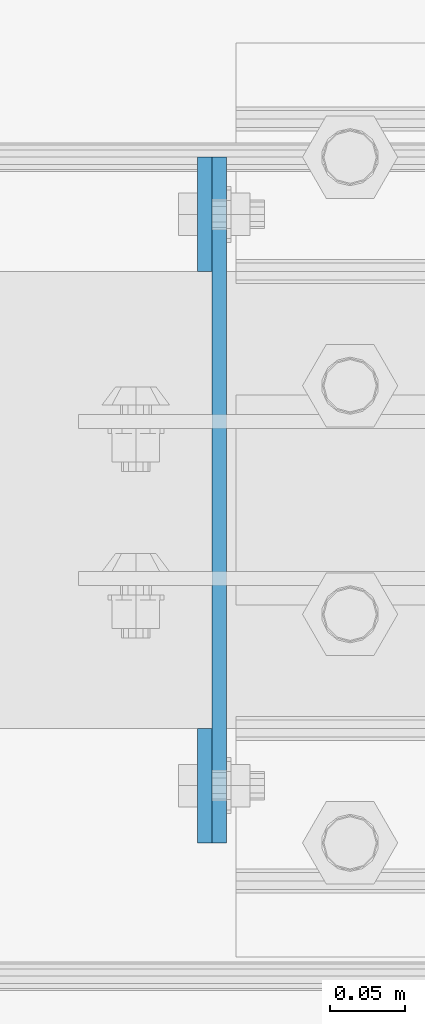
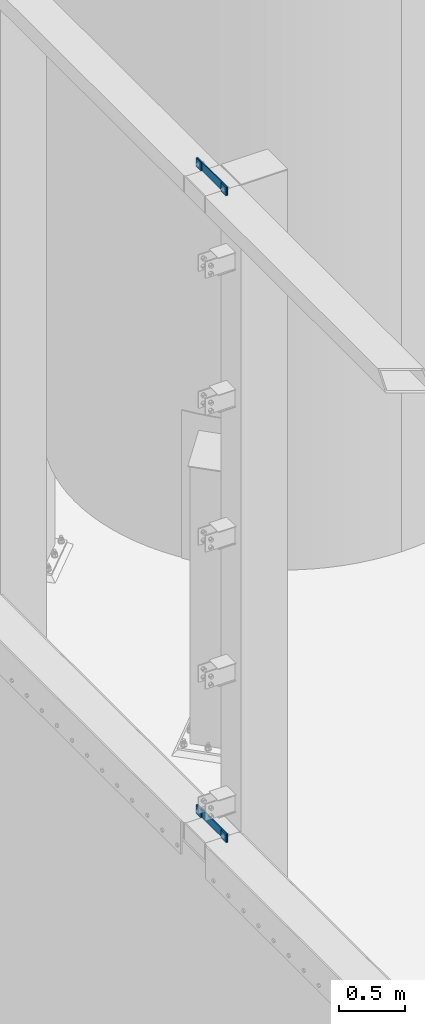
# One storey, part 1409 of 1876: 6 plates, 5 elements without a shape of their own.
"""IFC2X3 building model written with IfcOpenShell, lengths in millimetres."""

from ifc_helpers import new_model, si_unit, frame, origin_with_axes, place, context, subcontext, project, spatial, faceted_brep, material, type_object, element, aggregate, save


model = new_model("IFC2X3")

# Units and contexts
model_context = context("Model", 3, precision=1e-05, world=origin_with_axes())
body_context = subcontext(model_context, "Body", "Model", "MODEL_VIEW")
ifc_project = project(units=[si_unit("LENGTHUNIT", "METRE", prefix="MILLI"), si_unit("AREAUNIT", "SQUARE_METRE"), si_unit("VOLUMEUNIT", "CUBIC_METRE"), si_unit("MASSUNIT", "GRAM", prefix="KILO"), si_unit("TIMEUNIT", "SECOND"), si_unit("PLANEANGLEUNIT", "RADIAN"), si_unit("SOLIDANGLEUNIT", "STERADIAN"), si_unit("THERMODYNAMICTEMPERATUREUNIT", "DEGREE_CELSIUS"), si_unit("LUMINOUSINTENSITYUNIT", "LUMEN")], contexts=[model_context])

# Site, building, storey
site_placement = place(None, origin_with_axes())
site = spatial("IfcSite", under=ifc_project, at=site_placement, CompositionType="ELEMENT")
building_placement = place(site_placement, origin_with_axes())
building = spatial("IfcBuilding", under=site, at=building_placement, Name="Undefined", CompositionType="ELEMENT")
storey_placement = place(building_placement, origin_with_axes())
storey = spatial("IfcBuildingStorey", under=building, at=storey_placement, Name="Undefined", CompositionType="ELEMENT", Elevation=0.0)

# Assembly, plate
assembly_1_placement = place(storey_placement, origin_with_axes())
assembly_1 = element("IfcElementAssembly", 1, at=assembly_1_placement, inside=storey, Name="BEAM", AssemblyPlace="NOTDEFINED", PredefinedType="RIGID_FRAME")
ifc_material = material(Name="STEEL/A36")
plate_type = type_object("IfcPlateType", PredefinedType="NOTDEFINED")
plate_1_placement = place(assembly_1_placement, frame((-144.4625, -21894.8, 10667.9356518697), z_axis=(0.0, -1.0, 0.0), x_axis=(0.0, 0.0, 1.0)))
plate_1 = element("IfcPlate", 2, at=plate_1_placement, type_object=plate_type, material=ifc_material, Name="PLATE", context=body_context, shape_type="Brep", body=[
    faceted_brep([(0.0, -4.76249999999982, 0.0), (0.0643511861562729, -4.76249999999999, 76.1999969482422), (0.0643511861562729, 4.76249999999999, 76.1999969482422), (0.0, 4.76249999999982, 0.0), (76.2643508911133, -4.76249999999999, 76.1999969482422), (76.2643508911133, 4.76249999999999, 76.1999969482422), (76.2643508911133, -4.76249999999999, 0.0), (76.2643508911133, 4.76249999999999, 0.0)], [[[0, 1, 2, 3]], [[1, 4, 5, 2]], [[4, 6, 7, 5]], [[6, 0, 3, 7]], [[5, 7, 3, 2]], [[6, 4, 1, 0]]]),
])
aggregate(assembly_1, [plate_1])

assembly_2_placement = place(storey_placement, origin_with_axes())
assembly_2 = element("IfcElementAssembly", 3, at=assembly_2_placement, inside=storey, Name="BEAM", AssemblyPlace="NOTDEFINED", PredefinedType="RIGID_FRAME")
plate_2_placement = place(assembly_2_placement, frame((-144.4625, -21513.8, 10667.9356518697), z_axis=(0.0, -1.0, 0.0), x_axis=(0.0, 0.0, 1.0)))
plate_2 = element("IfcPlate", 4, at=plate_2_placement, type_object=plate_type, material=ifc_material, Name="PLATE", context=body_context, shape_type="Brep", body=[
    faceted_brep([(0.0, -4.76249999999982, 0.0), (0.0643511861562729, -4.76249999999999, 76.1999969482422), (0.0643511861562729, 4.76249999999999, 76.1999969482422), (0.0, 4.76249999999982, 0.0), (76.2643508911133, -4.76249999999999, 76.1999969482422), (76.2643508911133, 4.76249999999999, 76.1999969482422), (76.2643508911133, -4.76249999999999, 0.0), (76.2643508911133, 4.76249999999999, 0.0)], [[[0, 1, 2, 3]], [[1, 4, 5, 2]], [[4, 6, 7, 5]], [[6, 0, 3, 7]], [[5, 7, 3, 2]], [[6, 4, 1, 0]]]),
])
aggregate(assembly_2, [plate_2])

assembly_3_placement = place(storey_placement, origin_with_axes())
assembly_3 = element("IfcElementAssembly", 5, at=assembly_3_placement, inside=storey, Name="COLUMN", AssemblyPlace="NOTDEFINED", PredefinedType="RIGID_FRAME")
plate_3_placement = place(assembly_3_placement, frame((-134.9375, -21971.0, 10744.2), z_axis=(0.0, 1.0, 0.0), x_axis=(0.0, 0.0, -1.0)))
plate_3 = element("IfcPlate", 6, at=plate_3_placement, type_object=plate_type, material=ifc_material, Name="PLATE", context=body_context, shape_type="Brep", body=[
    faceted_brep([(0.0, -4.76249999999982, 0.0), (0.0, -4.76250000000073, 457.200012207031), (0.0, 4.76250000000073, 457.200012207031), (0.0, 4.76249999999982, 0.0), (76.1999969482422, -4.76250000000073, 457.200012207031), (76.1999969482422, 4.76250000000073, 457.200012207031), (76.1999969482422, -4.76250000000073, 0.0), (76.1999969482422, 4.76250000000073, 0.0)], [[[0, 1, 2, 3]], [[1, 4, 5, 2]], [[4, 6, 7, 5]], [[6, 0, 3, 7]], [[5, 7, 3, 2]], [[6, 4, 1, 0]]]),
])

assembly_4_placement = place(storey_placement, origin_with_axes())
assembly_4 = element("IfcElementAssembly", 7, at=assembly_4_placement, inside=storey, Name="BEAM", AssemblyPlace="NOTDEFINED", PredefinedType="RIGID_FRAME")
plate_4_placement = place(assembly_4_placement, frame((-144.4625, -21513.8, 4673.53565186968), z_axis=(0.0, -1.0, 0.0), x_axis=(0.0, 0.0, 1.0)))
plate_4 = element("IfcPlate", 8, at=plate_4_placement, type_object=plate_type, material=ifc_material, Name="PLATE", context=body_context, shape_type="Brep", body=[
    faceted_brep([(0.0, -4.76249999999982, 0.0), (0.0643511861562729, -4.76249999999999, 76.1999969482422), (0.0643511861562729, 4.76249999999999, 76.1999969482422), (0.0, 4.76249999999982, 0.0), (76.2643508911133, -4.76249999999999, 76.1999969482422), (76.2643508911133, 4.76249999999999, 76.1999969482422), (76.2643508911133, -4.76249999999999, 0.0), (76.2643508911133, 4.76249999999999, 0.0)], [[[0, 1, 2, 3]], [[1, 4, 5, 2]], [[4, 6, 7, 5]], [[6, 0, 3, 7]], [[5, 7, 3, 2]], [[6, 4, 1, 0]]]),
])
aggregate(assembly_4, [plate_4])

assembly_5_placement = place(storey_placement, origin_with_axes())
assembly_5 = element("IfcElementAssembly", 9, at=assembly_5_placement, inside=storey, Name="BEAM", AssemblyPlace="NOTDEFINED", PredefinedType="RIGID_FRAME")
plate_5_placement = place(assembly_5_placement, frame((-144.4625, -21894.8, 4673.53565186968), z_axis=(0.0, -1.0, 0.0), x_axis=(0.0, 0.0, 1.0)))
plate_5 = element("IfcPlate", 10, at=plate_5_placement, type_object=plate_type, material=ifc_material, Name="PLATE", context=body_context, shape_type="Brep", body=[
    faceted_brep([(0.0, -4.76249999999982, 0.0), (0.0643511861562729, -4.76249999999999, 76.1999969482422), (0.0643511861562729, 4.76249999999999, 76.1999969482422), (0.0, 4.76249999999982, 0.0), (76.2643508911133, -4.76249999999999, 76.1999969482422), (76.2643508911133, 4.76249999999999, 76.1999969482422), (76.2643508911133, -4.76249999999999, 0.0), (76.2643508911133, 4.76249999999999, 0.0)], [[[0, 1, 2, 3]], [[1, 4, 5, 2]], [[4, 6, 7, 5]], [[6, 0, 3, 7]], [[5, 7, 3, 2]], [[6, 4, 1, 0]]]),
])
aggregate(assembly_5, [plate_5])

# Plate
plate_6_placement = place(assembly_3_placement, frame((-134.9375, -21971.0, 4749.8), z_axis=(0.0, 1.0, 0.0), x_axis=(0.0, 0.0, -1.0)))
plate_6 = element("IfcPlate", 11, at=plate_6_placement, type_object=plate_type, material=ifc_material, Name="PLATE", context=body_context, shape_type="Brep", body=[
    faceted_brep([(0.0, -4.76249999999982, 0.0), (0.0, -4.76250000000073, 457.200012207031), (0.0, 4.76250000000073, 457.200012207031), (0.0, 4.76249999999982, 0.0), (76.1999969482422, -4.76250000000073, 457.200012207031), (76.1999969482422, 4.76250000000073, 457.200012207031), (76.1999969482422, -4.76250000000073, 0.0), (76.1999969482422, 4.76250000000073, 0.0)], [[[0, 1, 2, 3]], [[1, 4, 5, 2]], [[4, 6, 7, 5]], [[6, 0, 3, 7]], [[5, 7, 3, 2]], [[6, 4, 1, 0]]]),
])

aggregate(assembly_3, [plate_3, plate_6])

save(model, "model.ifc")
